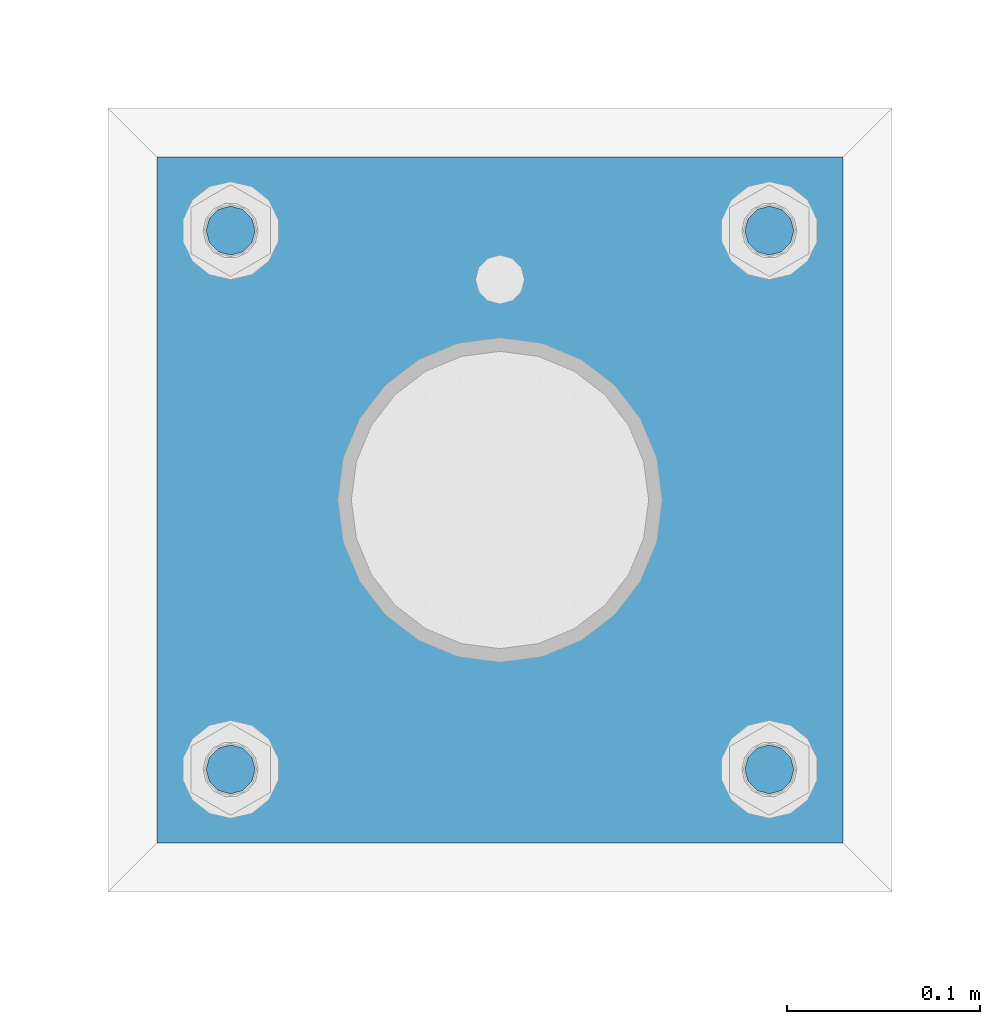
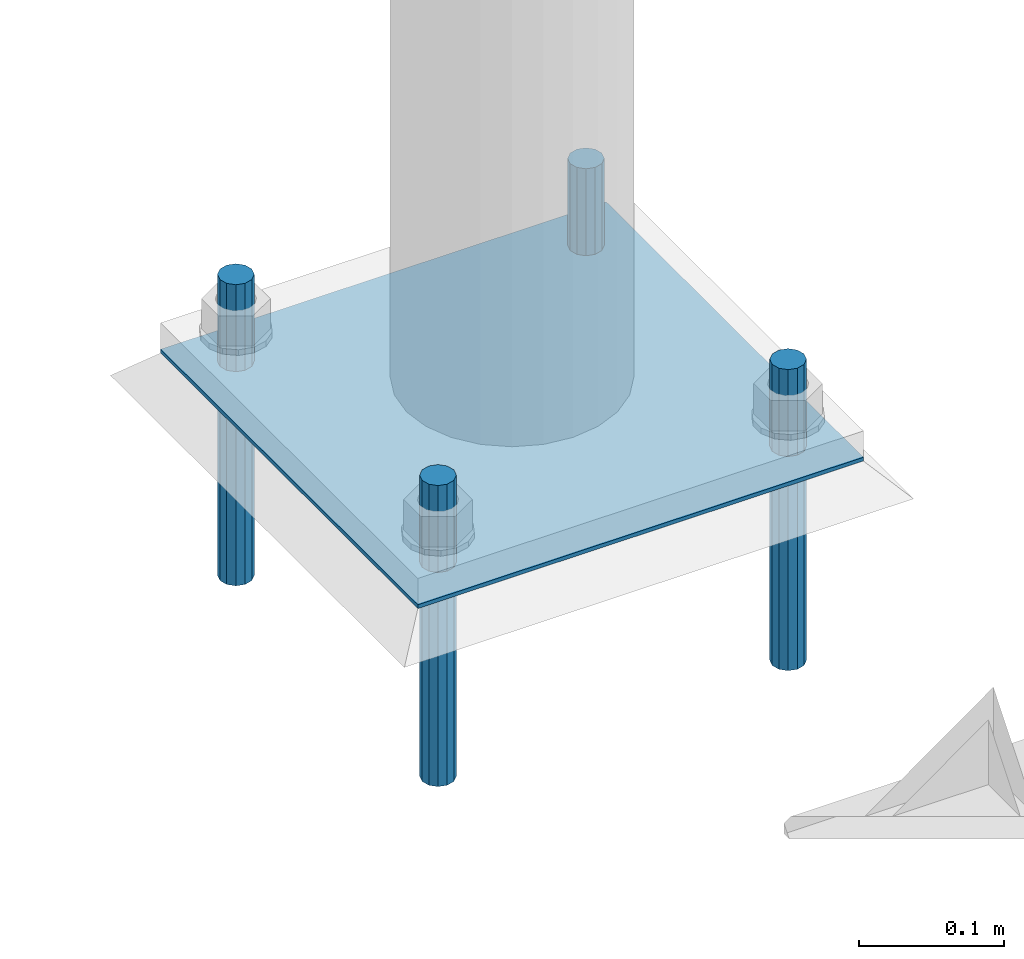
# One storey, part 2545 of 3843: 5 beams, 1 element without a shape of its own.
"""IFC2X3 building model written with IfcOpenShell, lengths in millimetres."""

from ifc_helpers import new_model, si_unit, frame, origin_with_axes, place, context, subcontext, project, spatial, faceted_brep, material, type_object, element, aggregate, save


model = new_model("IFC2X3")

# Units and contexts
model_context = context("Model", 3, precision=1e-05, world=origin_with_axes())
body_context = subcontext(model_context, "Body", "Model", "MODEL_VIEW")
ifc_project = project(units=[si_unit("LENGTHUNIT", "METRE", prefix="MILLI"), si_unit("AREAUNIT", "SQUARE_METRE"), si_unit("VOLUMEUNIT", "CUBIC_METRE"), si_unit("MASSUNIT", "GRAM", prefix="KILO"), si_unit("TIMEUNIT", "SECOND"), si_unit("PLANEANGLEUNIT", "RADIAN"), si_unit("SOLIDANGLEUNIT", "STERADIAN"), si_unit("THERMODYNAMICTEMPERATUREUNIT", "DEGREE_CELSIUS"), si_unit("LUMINOUSINTENSITYUNIT", "LUMEN")], contexts=[model_context])

# Site, building, storey
site_placement = place(None, origin_with_axes())
site = spatial("IfcSite", under=ifc_project, at=site_placement, CompositionType="ELEMENT")
building_placement = place(site_placement, origin_with_axes())
building = spatial("IfcBuilding", under=site, at=building_placement, Name="Undefined", CompositionType="ELEMENT")
storey_placement = place(building_placement, origin_with_axes())
storey = spatial("IfcBuildingStorey", under=building, at=storey_placement, Name="Undefined", CompositionType="ELEMENT", Elevation=0.0)

# Assembly, beams
assembly_placement = place(storey_placement, origin_with_axes())
assembly = element("IfcElementAssembly", 1, at=assembly_placement, inside=storey, Name="TEMPLATE", AssemblyPlace="NOTDEFINED", PredefinedType="RIGID_FRAME")
ifc_material_1 = material(Name="STEEL/316 SS")
beam_type_1 = type_object("IfcBeamType", PredefinedType="NOTDEFINED")
beam_1_placement = place(assembly_placement, frame((69735.7, 92989.4, 30581.6), z_axis=(1.0, 0.0, 0.0), x_axis=(0.0, 0.0, -1.0)))
beam_1 = element("IfcBeam", 2, at=beam_1_placement, type_object=beam_type_1, material=ifc_material_1, Name="ANCHOR_ROD", context=body_context, shape_type="Brep", body=[
    faceted_brep([(0.0, -12.6999999999971, 0.0), (0.0, -10.9985226280696, -6.34999999999854), (253.999, -10.9985226280696, -6.34999999999854), (253.999, -12.6999999999971, 0.0), (0.0, -6.35000000000582, -10.9985226280623), (253.999, -6.35000000000582, -10.9985226280623), (0.0, 0.0, -12.6999999999971), (253.999, 0.0, -12.6999999999971), (0.0, 6.35000000000582, -10.9985226280623), (253.999, 6.35000000000582, -10.9985226280623), (0.0, 10.9985226280696, -6.34999999999854), (253.999, 10.9985226280696, -6.34999999999854), (0.0, 12.6999999999971, 0.0), (253.999, 12.6999999999971, 0.0), (0.0, 10.9985226280696, 6.34999999999854), (253.999, 10.9985226280696, 6.34999999999854), (0.0, 6.35000000000582, 10.9985226280623), (253.999, 6.35000000000582, 10.9985226280623), (0.0, 0.0, 12.6999999999971), (253.999, 0.0, 12.6999999999971), (0.0, -6.35000000000582, 10.9985226280623), (253.999, -6.35000000000582, 10.9985226280623), (0.0, -10.9985226280696, 6.34999999999854), (253.999, -10.9985226280696, 6.34999999999854)], [[[0, 1, 2, 3]], [[1, 4, 5, 2]], [[4, 6, 7, 5]], [[6, 8, 9, 7]], [[8, 10, 11, 9]], [[10, 12, 13, 11]], [[12, 14, 15, 13]], [[14, 16, 17, 15]], [[16, 18, 19, 17]], [[18, 20, 21, 19]], [[20, 22, 23, 21]], [[22, 0, 3, 23]], [[5, 7, 9, 11, 13, 15, 17, 19, 21, 23, 3, 2]], [[22, 20, 18, 16, 14, 12, 10, 8, 6, 4, 1, 0]]]),
])
beam_2_placement = place(assembly_placement, frame((69735.7, 93268.8, 30581.6), z_axis=(-1.0, 0.0, 0.0), x_axis=(0.0, 0.0, -1.0)))
beam_2 = element("IfcBeam", 3, at=beam_2_placement, type_object=beam_type_1, material=ifc_material_1, Name="ANCHOR_ROD", context=body_context, shape_type="Brep", body=[
    faceted_brep([(0.0, -12.6999999999971, 0.0), (0.0, -10.9985226280696, -6.34999999999854), (253.999, -10.9985226280696, -6.34999999999854), (253.999, -12.6999999999971, 0.0), (0.0, -6.35000000000582, -10.9985226280623), (253.999, -6.35000000000582, -10.9985226280623), (0.0, 0.0, -12.6999999999971), (253.999, 0.0, -12.6999999999971), (0.0, 6.35000000000582, -10.9985226280623), (253.999, 6.35000000000582, -10.9985226280623), (0.0, 10.9985226280696, -6.34999999999854), (253.999, 10.9985226280696, -6.34999999999854), (0.0, 12.6999999999971, 0.0), (253.999, 12.6999999999971, 0.0), (0.0, 10.9985226280696, 6.34999999999854), (253.999, 10.9985226280696, 6.34999999999854), (0.0, 6.35000000000582, 10.9985226280623), (253.999, 6.35000000000582, 10.9985226280623), (0.0, 0.0, 12.6999999999971), (253.999, 0.0, 12.6999999999971), (0.0, -6.35000000000582, 10.9985226280623), (253.999, -6.35000000000582, 10.9985226280623), (0.0, -10.9985226280696, 6.34999999999854), (253.999, -10.9985226280696, 6.34999999999854)], [[[0, 1, 2, 3]], [[1, 4, 5, 2]], [[4, 6, 7, 5]], [[6, 8, 9, 7]], [[8, 10, 11, 9]], [[10, 12, 13, 11]], [[12, 14, 15, 13]], [[14, 16, 17, 15]], [[16, 18, 19, 17]], [[18, 20, 21, 19]], [[20, 22, 23, 21]], [[22, 0, 3, 23]], [[5, 7, 9, 11, 13, 15, 17, 19, 21, 23, 3, 2]], [[22, 20, 18, 16, 14, 12, 10, 8, 6, 4, 1, 0]]]),
])
beam_3_placement = place(assembly_placement, frame((69456.3, 92989.4, 30581.6), z_axis=(1.0, 0.0, 0.0), x_axis=(0.0, 0.0, -1.0)))
beam_3 = element("IfcBeam", 4, at=beam_3_placement, type_object=beam_type_1, material=ifc_material_1, Name="ANCHOR_ROD", context=body_context, shape_type="Brep", body=[
    faceted_brep([(0.0, -12.6999999999971, 0.0), (0.0, -10.9985226280696, -6.34999999999854), (253.999, -10.9985226280696, -6.34999999999854), (253.999, -12.6999999999971, 0.0), (0.0, -6.35000000000582, -10.9985226280623), (253.999, -6.35000000000582, -10.9985226280623), (0.0, 0.0, -12.6999999999971), (253.999, 0.0, -12.6999999999971), (0.0, 6.35000000000582, -10.9985226280623), (253.999, 6.35000000000582, -10.9985226280623), (0.0, 10.9985226280696, -6.34999999999854), (253.999, 10.9985226280696, -6.34999999999854), (0.0, 12.6999999999971, 0.0), (253.999, 12.6999999999971, 0.0), (0.0, 10.9985226280696, 6.34999999999854), (253.999, 10.9985226280696, 6.34999999999854), (0.0, 6.35000000000582, 10.9985226280623), (253.999, 6.35000000000582, 10.9985226280623), (0.0, 0.0, 12.6999999999971), (253.999, 0.0, 12.6999999999971), (0.0, -6.35000000000582, 10.9985226280623), (253.999, -6.35000000000582, 10.9985226280623), (0.0, -10.9985226280696, 6.34999999999854), (253.999, -10.9985226280696, 6.34999999999854)], [[[0, 1, 2, 3]], [[1, 4, 5, 2]], [[4, 6, 7, 5]], [[6, 8, 9, 7]], [[8, 10, 11, 9]], [[10, 12, 13, 11]], [[12, 14, 15, 13]], [[14, 16, 17, 15]], [[16, 18, 19, 17]], [[18, 20, 21, 19]], [[20, 22, 23, 21]], [[22, 0, 3, 23]], [[5, 7, 9, 11, 13, 15, 17, 19, 21, 23, 3, 2]], [[22, 20, 18, 16, 14, 12, 10, 8, 6, 4, 1, 0]]]),
])
beam_4_placement = place(assembly_placement, frame((69456.3, 93268.8, 30581.6), z_axis=(-1.0, 0.0, 0.0), x_axis=(0.0, 0.0, -1.0)))
beam_4 = element("IfcBeam", 5, at=beam_4_placement, type_object=beam_type_1, material=ifc_material_1, Name="ANCHOR_ROD", context=body_context, shape_type="Brep", body=[
    faceted_brep([(0.0, -12.6999999999971, 0.0), (0.0, -10.9985226280696, -6.34999999999854), (253.999, -10.9985226280696, -6.34999999999854), (253.999, -12.6999999999971, 0.0), (0.0, -6.35000000000582, -10.9985226280623), (253.999, -6.35000000000582, -10.9985226280623), (0.0, 0.0, -12.6999999999971), (253.999, 0.0, -12.6999999999971), (0.0, 6.35000000000582, -10.9985226280623), (253.999, 6.35000000000582, -10.9985226280623), (0.0, 10.9985226280696, -6.34999999999854), (253.999, 10.9985226280696, -6.34999999999854), (0.0, 12.6999999999971, 0.0), (253.999, 12.6999999999971, 0.0), (0.0, 10.9985226280696, 6.34999999999854), (253.999, 10.9985226280696, 6.34999999999854), (0.0, 6.35000000000582, 10.9985226280623), (253.999, 6.35000000000582, 10.9985226280623), (0.0, 0.0, 12.6999999999971), (253.999, 0.0, 12.6999999999971), (0.0, -6.35000000000582, 10.9985226280623), (253.999, -6.35000000000582, 10.9985226280623), (0.0, -10.9985226280696, 6.34999999999854), (253.999, -10.9985226280696, 6.34999999999854)], [[[0, 1, 2, 3]], [[1, 4, 5, 2]], [[4, 6, 7, 5]], [[6, 8, 9, 7]], [[8, 10, 11, 9]], [[10, 12, 13, 11]], [[12, 14, 15, 13]], [[14, 16, 17, 15]], [[16, 18, 19, 17]], [[18, 20, 21, 19]], [[20, 22, 23, 21]], [[22, 0, 3, 23]], [[5, 7, 9, 11, 13, 15, 17, 19, 21, 23, 3, 2]], [[22, 20, 18, 16, 14, 12, 10, 8, 6, 4, 1, 0]]]),
])
ifc_material_2 = material(Name="STEEL/A36")
beam_type_2 = type_object("IfcBeamType", PredefinedType="NOTDEFINED")
beam_5_placement = place(assembly_placement, frame((69773.8, 93129.1, 30506.9875), z_axis=(0.0, -1.0, 0.0), x_axis=(-1.0, 0.0, 0.0)))
beam_5 = element("IfcBeam", 6, at=beam_5_placement, type_object=beam_type_2, material=ifc_material_2, Name="TEMPLATE", context=body_context, shape_type="Brep", body=[
    faceted_brep([(0.0, 1.58750000000146, -177.800000000003), (0.0, 1.58750000000146, 177.800000000003), (355.600000000006, 1.58750000000146, 177.800000000003), (355.600000000006, 1.58750000000146, -177.800000000003), (0.0, -1.58750000000146, 177.800000000003), (355.600000000006, -1.58750000000146, 177.800000000003), (0.0, -1.58750000000146, -177.800000000003), (355.600000000006, -1.58750000000146, -177.800000000003)], [[[0, 1, 2, 3]], [[1, 4, 5, 2]], [[4, 6, 7, 5]], [[6, 0, 3, 7]], [[5, 7, 3, 2]], [[6, 4, 1, 0]]]),
])
aggregate(assembly, [beam_1, beam_2, beam_3, beam_4, beam_5])

save(model, "model.ifc")
